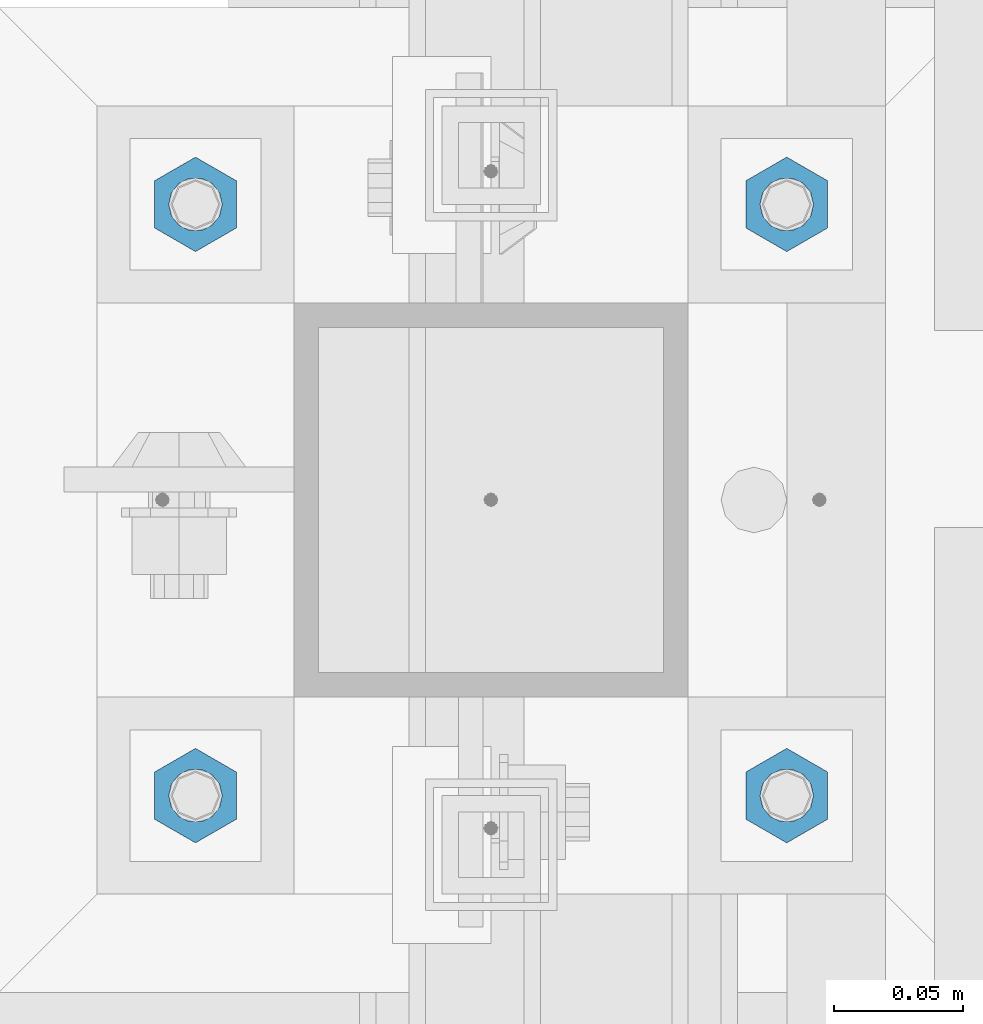
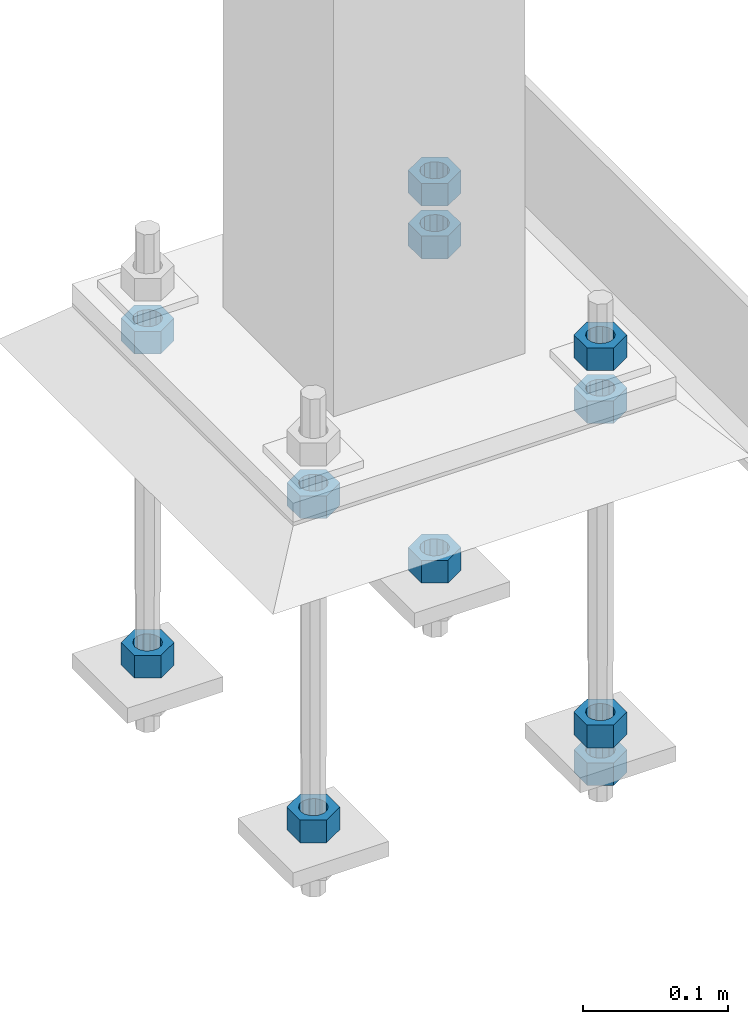
# One storey, part 2810 of 3843: 11 beams, 1 element without a shape of its own.
"""IFC2X3 building model written with IfcOpenShell, lengths in millimetres."""

import ifcopenshell
import ifcopenshell.guid

model = None  # the IFC model being written
_history = None  # IfcOwnerHistory: only IFC2X3 demands one
_inside = {}  # id of a spatial element -> (the spatial element, [elements in it])
_under = {}  # id of a project, library or spatial element -> (it, [spatial elements below it])
_declared = {}  # id of a project -> (the project, [libraries it declares])
_typed = {}  # id of a type object -> (the type object, [elements of that type])
_made_of = {}  # id of a material, layer set ... -> (it, [elements and type objects made of it])


def new_model(schema):
    """Start an empty IFC model of exactly this schema.

    Asked for "IFC4X3", IfcOpenShell would pick the latest addendum, in which some entities
    have other attributes; the version numbers below select the first issue.
    IFC2X3 requires an IfcOwnerHistory on every rooted entity: one is made here for all.
    """
    global model, _history
    if schema == "IFC4X3":
        model = ifcopenshell.file(schema_version=(4, 3, 0, 0))
    else:
        model = ifcopenshell.file(schema=schema)
    _inside.clear()
    _under.clear()
    _declared.clear()
    _typed.clear()
    _made_of.clear()
    _history = None
    if model.schema == "IFC2X3":
        org = make("IfcOrganization", Name="unknown")
        user = make(
            "IfcPersonAndOrganization",
            ThePerson=make("IfcPerson", FamilyName="unknown"),
            TheOrganization=org,
        )
        app = make(
            "IfcApplication",
            ApplicationDeveloper=org,
            Version="unknown",
            ApplicationFullName="unknown",
            ApplicationIdentifier="unknown",
        )
        _history = make(
            "IfcOwnerHistory",
            OwningUser=user,
            OwningApplication=app,
            ChangeAction="ADDED",
            CreationDate=0,
        )
    return model


def make(cls, **values):
    """One entity of the class cls with the attributes given. An attribute that is None is left unset."""
    return model.create_entity(
        cls, **{name: value for name, value in values.items() if value is not None}
    )


def rooted(cls, **values):
    """An entity with a GlobalId (a new one), such as an element, a storey or a relation."""
    return make(cls, GlobalId=ifcopenshell.guid.new(), OwnerHistory=_history, **values)


def si_unit(unit_type, name, prefix=None):
    """IfcSIUnit, for example si_unit("LENGTHUNIT", "METRE", prefix="MILLI")."""
    return make("IfcSIUnit", UnitType=unit_type, Prefix=prefix, Name=name)


def assignment(units):
    """IfcUnitAssignment: the units of a project."""
    return None if units is None else make("IfcUnitAssignment", Units=units)


def point(xyz):
    """IfcCartesianPoint."""
    return None if xyz is None else make("IfcCartesianPoint", Coordinates=xyz)


def direction(xyz):
    """IfcDirection."""
    return None if xyz is None else make("IfcDirection", DirectionRatios=xyz)


def frame(location, z_axis=None, x_axis=None):
    """IfcAxis2Placement3D, a coordinate frame: its origin and axes. An axis left out is left unset."""
    return make(
        "IfcAxis2Placement3D",
        Location=point(location),
        Axis=direction(z_axis),
        RefDirection=direction(x_axis),
    )


def origin_with_axes():
    """The frame at (0, 0, 0) with the z axis (0, 0, 1) and the x axis (1, 0, 0) written out."""
    return frame((0.0, 0.0, 0.0), z_axis=(0.0, 0.0, 1.0), x_axis=(1.0, 0.0, 0.0))


def place(relative_to, where):
    """IfcLocalPlacement: puts the frame where relative to a parent placement (None: the world)."""
    return make(
        "IfcLocalPlacement", PlacementRelTo=relative_to, RelativePlacement=where
    )


def context(
    kind, dimensions, precision=None, world=None, true_north=None, identifier=None
):
    """IfcGeometricRepresentationContext, for example the 3D "Model" context."""
    return make(
        "IfcGeometricRepresentationContext",
        ContextIdentifier=identifier,
        ContextType=kind,
        CoordinateSpaceDimension=dimensions,
        Precision=precision,
        WorldCoordinateSystem=world,
        TrueNorth=true_north,
    )


def subcontext(parent, identifier, kind, view, scale=None):
    """IfcGeometricRepresentationSubContext, for example "Body" below "Model"."""
    return make(
        "IfcGeometricRepresentationSubContext",
        ContextIdentifier=identifier,
        ContextType=kind,
        ParentContext=parent,
        TargetScale=scale,
        TargetView=view,
    )


def project(units=None, contexts=None):
    """IfcProject with its units and contexts."""
    return rooted(
        "IfcProject",
        Name="project",
        RepresentationContexts=contexts,
        UnitsInContext=assignment(units),
    )


def spatial(cls, under=None, at=None, **own):
    """A site, building, storey or space (cls), placed at a placement, below another one or the project."""
    s = rooted(cls, ObjectPlacement=at, **own)
    if under is not None:
        _under.setdefault(under.id(), (under, []))[1].append(s)
    return s


def faces_of(points, faces, orient=None, outer=None):
    """IfcFace entities. A face is a list of loops; a loop is a list of indices into points, from 0.

    orient and outer hold one flag for each loop. By default every Orientation is true, the
    first loop of a face is its IfcFaceOuterBound and the others are IfcFaceBound.
    """
    made = []
    for i, loops in enumerate(faces):
        bounds = []
        for j, loop in enumerate(loops):
            is_outer = j == 0 if outer is None else outer[i][j]
            bounds.append(
                make(
                    "IfcFaceOuterBound" if is_outer else "IfcFaceBound",
                    Bound=make("IfcPolyLoop", Polygon=[points[k] for k in loop]),
                    Orientation=True if orient is None else orient[i][j],
                )
            )
        made.append(make("IfcFace", Bounds=bounds))
    return made


def faceted_brep(points, faces, orient=None, outer=None, voids=None):
    """IfcFacetedBrep: a solid bounded by flat faces; with voids (closed shells), ...WithVoids."""
    shared = [point(p) for p in points]
    hull = make("IfcClosedShell", CfsFaces=faces_of(shared, faces, orient, outer))
    if voids is None:
        return make("IfcFacetedBrep", Outer=hull)
    return make(
        "IfcFacetedBrepWithVoids",
        Outer=hull,
        Voids=[
            make(cls, CfsFaces=faces_of(shared, fs, o, b)) for cls, fs, o, b in voids
        ],
    )


def shape(context_of_items, identifier, shape_type, items):
    """IfcShapeRepresentation: the items that make up one representation, for example the "Body"."""
    return make(
        "IfcShapeRepresentation",
        ContextOfItems=context_of_items,
        RepresentationIdentifier=identifier,
        RepresentationType=shape_type,
        Items=items,
    )


def material(Name=None, Category=None):
    """IfcMaterial."""
    return make("IfcMaterial", Name=Name, Category=Category)


def made_of(thing, what):
    """Note that an element or type object is made of a material, layer set ...; save() writes the relation."""
    if what is not None:
        _made_of.setdefault(what.id(), (what, []))[1].append(thing)
    return thing


def type_object(cls, material=None, **own):
    """A type object (cls), such as IfcWallType, which elements share."""
    return made_of(rooted(cls, **own), material)


def element(
    cls,
    number,
    at=None,
    inside=None,
    cuts=None,
    type_object=None,
    material=None,
    context=None,
    identifier="Body",
    shape_type=None,
    held_by="IfcProductDefinitionShape",
    body=None,
    shapes=None,
    **own,
):
    """One element of the class cls, such as IfcWall. Its Tag is "e" and its number.

    at: its placement. inside: the storey or other place that contains it. cuts: it is an
    opening in that element (IfcRelVoidsElement). A single representation is given by context,
    identifier, shape_type and body (its items); several are given by shapes. held_by: the class
    of the entity that holds the representations. save() writes the other relations.
    """
    e = rooted(cls, Tag="e%d" % number, ObjectPlacement=at, **own)
    if body is not None:
        shapes = [shape(context, identifier, shape_type, body)]
    if shapes is not None:
        e.Representation = make(held_by, Representations=shapes)
    if inside is not None:
        _inside.setdefault(inside.id(), (inside, []))[1].append(e)
    if cuts is not None:
        rooted(
            "IfcRelVoidsElement", RelatingBuildingElement=cuts, RelatedOpeningElement=e
        )
    if type_object is not None:
        _typed.setdefault(type_object.id(), (type_object, []))[1].append(e)
    return made_of(e, material)


def aggregate(whole, parts):
    """IfcRelAggregates: a whole, such as a stair, and the parts it consists of."""
    return rooted("IfcRelAggregates", RelatingObject=whole, RelatedObjects=parts)


def save(model, path):
    """Write the relations noted so far, then the file.

    IfcRelAggregates (storeys below a building ...), IfcRelContainedInSpatialStructure (elements
    in a storey), IfcRelDefinesByType, IfcRelAssociatesMaterial and IfcRelDeclares: one each for
    every whole, place, type object, material and project.
    """
    for whole, parts in _under.values():
        aggregate(whole, parts)
    for where, things in _inside.values():
        rooted(
            "IfcRelContainedInSpatialStructure",
            RelatedElements=things,
            RelatingStructure=where,
        )
    for kind, things in _typed.values():
        rooted("IfcRelDefinesByType", RelatedObjects=things, RelatingType=kind)
    for what, things in _made_of.values():
        rooted("IfcRelAssociatesMaterial", RelatedObjects=things, RelatingMaterial=what)
    for by, libraries in _declared.values():
        rooted("IfcRelDeclares", RelatingContext=by, RelatedDefinitions=libraries)
    model.write(path)


model = new_model("IFC2X3")

# Units and contexts
model_context = context("Model", 3, precision=1e-05, world=origin_with_axes())
body_context = subcontext(model_context, "Body", "Model", "MODEL_VIEW")
ifc_project = project(units=[si_unit("LENGTHUNIT", "METRE", prefix="MILLI"), si_unit("AREAUNIT", "SQUARE_METRE"), si_unit("VOLUMEUNIT", "CUBIC_METRE"), si_unit("MASSUNIT", "GRAM", prefix="KILO"), si_unit("TIMEUNIT", "SECOND"), si_unit("PLANEANGLEUNIT", "RADIAN"), si_unit("SOLIDANGLEUNIT", "STERADIAN"), si_unit("THERMODYNAMICTEMPERATUREUNIT", "DEGREE_CELSIUS"), si_unit("LUMINOUSINTENSITYUNIT", "LUMEN")], contexts=[model_context])

# Site, building, storey
site_placement = place(None, origin_with_axes())
site = spatial("IfcSite", under=ifc_project, at=site_placement, CompositionType="ELEMENT")
building_placement = place(site_placement, origin_with_axes())
building = spatial("IfcBuilding", under=site, at=building_placement, Name="Undefined", CompositionType="ELEMENT")
storey_placement = place(building_placement, origin_with_axes())
storey = spatial("IfcBuildingStorey", under=building, at=storey_placement, Name="Undefined", CompositionType="ELEMENT", Elevation=0.0)

# Assembly, beams
assembly_placement = place(storey_placement, origin_with_axes())
assembly = element("IfcElementAssembly", 1, at=assembly_placement, inside=storey, Name="TEMPLATE", AssemblyPlace="NOTDEFINED", PredefinedType="RIGID_FRAME")
ifc_material = material(Name="STEEL/A36")
beam_type = type_object("IfcBeamType", Name="3/4_HEAVY_HEX_NUT", PredefinedType="NOTDEFINED")
beam_1_placement = place(assembly_placement, frame((53105.05, 20193.0, 30518.1), z_axis=(1.0, 0.0, 0.0), x_axis=(0.0, 0.0, -1.0)))
beam_1 = element("IfcBeam", 2, at=beam_1_placement, type_object=beam_type, material=ifc_material, Name="NUT", ObjectType="3/4_HEAVY_HEX_NUT", context=body_context, shape_type="Brep", body=[
    faceted_brep([(0.0, -18.2600002288818, 0.0), (0.0, -9.13000011444092, -15.8100004196167), (19.0500000000029, -9.13000011444092, -15.8100004196167), (19.0500000000029, -18.2600002288818, 0.0), (0.0, 9.13000011444092, -15.8100004196167), (19.0500000000029, 9.13000011444092, -15.8100004196167), (0.0, 18.2600002288818, 0.0), (19.0500000000029, 18.2600002288818, 0.0), (0.0, 9.13000011444092, 15.8100004196167), (19.0500000000029, 9.13000011444092, 15.8100004196167), (0.0, -9.13000011444092, 15.8100004196167), (19.0500000000029, -9.13000011444092, 15.8100004196167), (0.0, 0.0, 10.3199996948242), (0.0, 4.47768005527905, 9.29799844179797), (19.0500000000029, 4.47768005527905, 9.29799844179797), (19.0500000000029, 0.0, 10.3199996948242), (0.0, 8.06850066047627, 6.43441456490837), (19.0500000000029, 8.06850066047627, 6.43441456490837), (0.0, 10.0612557561908, 2.2964159705225), (19.0500000000029, 10.0612557561908, 2.2964159705225), (0.0, 10.0612557561908, -2.2964159705225), (19.0500000000029, 10.0612557561908, -2.2964159705225), (0.0, 8.06850066047627, -6.43441456490837), (19.0500000000029, 8.06850066047627, -6.43441456490837), (0.0, 4.47768005527905, -9.29799844179797), (19.0500000000029, 4.47768005527905, -9.29799844179797), (0.0, 0.0, -10.3199996948242), (19.0500000000029, 0.0, -10.3199996948242), (0.0, -4.47768005527905, -9.29799844179797), (19.0500000000029, -4.47768005527905, -9.29799844179797), (0.0, -8.06850066047627, -6.43441456490837), (19.0500000000029, -8.06850066047627, -6.43441456490837), (0.0, -10.0612557561908, -2.2964159705225), (19.0500000000029, -10.0612557561908, -2.2964159705225), (0.0, -10.0612557561908, 2.2964159705225), (19.0500000000029, -10.0612557561908, 2.2964159705225), (0.0, -8.06850066047627, 6.43441456490837), (19.0500000000029, -8.06850066047627, 6.43441456490837), (0.0, -4.47768005527905, 9.29799844179797), (19.0500000000029, -4.47768005527905, 9.29799844179797)], [[[0, 1, 2, 3]], [[1, 4, 5, 2]], [[4, 6, 7, 5]], [[6, 8, 9, 7]], [[8, 10, 11, 9]], [[10, 0, 3, 11]], [[12, 13, 14, 15]], [[13, 16, 17, 14]], [[16, 18, 19, 17]], [[18, 20, 21, 19]], [[20, 22, 23, 21]], [[22, 24, 25, 23]], [[24, 26, 27, 25]], [[26, 28, 29, 27]], [[28, 30, 31, 29]], [[30, 32, 33, 31]], [[32, 34, 35, 33]], [[34, 36, 37, 35]], [[36, 38, 39, 37]], [[38, 12, 15, 39]], [[5, 7, 9, 11, 3, 2], [17, 19, 21, 23, 25, 27, 29, 31, 33, 35, 37, 39, 15, 14]], [[10, 8, 6, 4, 1, 0], [38, 36, 34, 32, 30, 28, 26, 24, 22, 20, 18, 16, 13, 12]]]),
])
beam_2_placement = place(assembly_placement, frame((53105.05, 20193.0, 30245.05), z_axis=(1.0, 0.0, 0.0), x_axis=(0.0, 0.0, -1.0)))
beam_2 = element("IfcBeam", 3, at=beam_2_placement, type_object=beam_type, material=ifc_material, Name="NUT", ObjectType="3/4_HEAVY_HEX_NUT", context=body_context, shape_type="Brep", body=[
    faceted_brep([(0.0, -18.2600002288818, 0.0), (0.0, -9.13000011444092, -15.8100004196167), (19.0500000000029, -9.13000011444092, -15.8100004196167), (19.0500000000029, -18.2600002288818, 0.0), (0.0, 9.13000011444092, -15.8100004196167), (19.0500000000029, 9.13000011444092, -15.8100004196167), (0.0, 18.2600002288818, 0.0), (19.0500000000029, 18.2600002288818, 0.0), (0.0, 9.13000011444092, 15.8100004196167), (19.0500000000029, 9.13000011444092, 15.8100004196167), (0.0, -9.13000011444092, 15.8100004196167), (19.0500000000029, -9.13000011444092, 15.8100004196167), (0.0, 0.0, 10.3199996948242), (0.0, 4.47768005527905, 9.29799844179797), (19.0500000000029, 4.47768005527905, 9.29799844179797), (19.0500000000029, 0.0, 10.3199996948242), (0.0, 8.06850066047627, 6.43441456490837), (19.0500000000029, 8.06850066047627, 6.43441456490837), (0.0, 10.0612557561908, 2.2964159705225), (19.0500000000029, 10.0612557561908, 2.2964159705225), (0.0, 10.0612557561908, -2.2964159705225), (19.0500000000029, 10.0612557561908, -2.2964159705225), (0.0, 8.06850066047627, -6.43441456490837), (19.0500000000029, 8.06850066047627, -6.43441456490837), (0.0, 4.47768005527905, -9.29799844179797), (19.0500000000029, 4.47768005527905, -9.29799844179797), (0.0, 0.0, -10.3199996948242), (19.0500000000029, 0.0, -10.3199996948242), (0.0, -4.47768005527905, -9.29799844179797), (19.0500000000029, -4.47768005527905, -9.29799844179797), (0.0, -8.06850066047627, -6.43441456490837), (19.0500000000029, -8.06850066047627, -6.43441456490837), (0.0, -10.0612557561908, -2.2964159705225), (19.0500000000029, -10.0612557561908, -2.2964159705225), (0.0, -10.0612557561908, 2.2964159705225), (19.0500000000029, -10.0612557561908, 2.2964159705225), (0.0, -8.06850066047627, 6.43441456490837), (19.0500000000029, -8.06850066047627, 6.43441456490837), (0.0, -4.47768005527905, 9.29799844179797), (19.0500000000029, -4.47768005527905, 9.29799844179797)], [[[0, 1, 2, 3]], [[1, 4, 5, 2]], [[4, 6, 7, 5]], [[6, 8, 9, 7]], [[8, 10, 11, 9]], [[10, 0, 3, 11]], [[12, 13, 14, 15]], [[13, 16, 17, 14]], [[16, 18, 19, 17]], [[18, 20, 21, 19]], [[20, 22, 23, 21]], [[22, 24, 25, 23]], [[24, 26, 27, 25]], [[26, 28, 29, 27]], [[28, 30, 31, 29]], [[30, 32, 33, 31]], [[32, 34, 35, 33]], [[34, 36, 37, 35]], [[36, 38, 39, 37]], [[38, 12, 15, 39]], [[5, 7, 9, 11, 3, 2], [17, 19, 21, 23, 25, 27, 29, 31, 33, 35, 37, 39, 15, 14]], [[10, 8, 6, 4, 1, 0], [38, 36, 34, 32, 30, 28, 26, 24, 22, 20, 18, 16, 13, 12]]]),
])
beam_3_placement = place(assembly_placement, frame((53105.05, 20421.6, 30518.1), z_axis=(-1.0, 0.0, 0.0), x_axis=(0.0, 0.0, -1.0)))
beam_3 = element("IfcBeam", 4, at=beam_3_placement, type_object=beam_type, material=ifc_material, Name="NUT", ObjectType="3/4_HEAVY_HEX_NUT", context=body_context, shape_type="Brep", body=[
    faceted_brep([(0.0, -18.2600002288818, 0.0), (0.0, -9.13000011444092, -15.8100004196167), (19.0500000000029, -9.13000011444092, -15.8100004196167), (19.0500000000029, -18.2600002288818, 0.0), (0.0, 9.13000011444092, -15.8100004196167), (19.0500000000029, 9.13000011444092, -15.8100004196167), (0.0, 18.2600002288818, 0.0), (19.0500000000029, 18.2600002288818, 0.0), (0.0, 9.13000011444092, 15.8100004196167), (19.0500000000029, 9.13000011444092, 15.8100004196167), (0.0, -9.13000011444092, 15.8100004196167), (19.0500000000029, -9.13000011444092, 15.8100004196167), (0.0, 0.0, 10.3199996948242), (0.0, 4.47768005527905, 9.29799844179797), (19.0500000000029, 4.47768005527905, 9.29799844179797), (19.0500000000029, 0.0, 10.3199996948242), (0.0, 8.06850066047627, 6.43441456490837), (19.0500000000029, 8.06850066047627, 6.43441456490837), (0.0, 10.0612557561908, 2.2964159705225), (19.0500000000029, 10.0612557561908, 2.2964159705225), (0.0, 10.0612557561908, -2.2964159705225), (19.0500000000029, 10.0612557561908, -2.2964159705225), (0.0, 8.06850066047627, -6.43441456490837), (19.0500000000029, 8.06850066047627, -6.43441456490837), (0.0, 4.47768005527905, -9.29799844179797), (19.0500000000029, 4.47768005527905, -9.29799844179797), (0.0, 0.0, -10.3199996948242), (19.0500000000029, 0.0, -10.3199996948242), (0.0, -4.47768005527905, -9.29799844179797), (19.0500000000029, -4.47768005527905, -9.29799844179797), (0.0, -8.06850066047627, -6.43441456490837), (19.0500000000029, -8.06850066047627, -6.43441456490837), (0.0, -10.0612557561908, -2.2964159705225), (19.0500000000029, -10.0612557561908, -2.2964159705225), (0.0, -10.0612557561908, 2.2964159705225), (19.0500000000029, -10.0612557561908, 2.2964159705225), (0.0, -8.06850066047627, 6.43441456490837), (19.0500000000029, -8.06850066047627, 6.43441456490837), (0.0, -4.47768005527905, 9.29799844179797), (19.0500000000029, -4.47768005527905, 9.29799844179797)], [[[0, 1, 2, 3]], [[1, 4, 5, 2]], [[4, 6, 7, 5]], [[6, 8, 9, 7]], [[8, 10, 11, 9]], [[10, 0, 3, 11]], [[12, 13, 14, 15]], [[13, 16, 17, 14]], [[16, 18, 19, 17]], [[18, 20, 21, 19]], [[20, 22, 23, 21]], [[22, 24, 25, 23]], [[24, 26, 27, 25]], [[26, 28, 29, 27]], [[28, 30, 31, 29]], [[30, 32, 33, 31]], [[32, 34, 35, 33]], [[34, 36, 37, 35]], [[36, 38, 39, 37]], [[38, 12, 15, 39]], [[5, 7, 9, 11, 3, 2], [17, 19, 21, 23, 25, 27, 29, 31, 33, 35, 37, 39, 15, 14]], [[10, 8, 6, 4, 1, 0], [38, 36, 34, 32, 30, 28, 26, 24, 22, 20, 18, 16, 13, 12]]]),
])
beam_4_placement = place(assembly_placement, frame((53105.05, 20421.6, 30245.05), z_axis=(-1.0, 0.0, 0.0), x_axis=(0.0, 0.0, -1.0)))
beam_4 = element("IfcBeam", 5, at=beam_4_placement, type_object=beam_type, material=ifc_material, Name="NUT", ObjectType="3/4_HEAVY_HEX_NUT", context=body_context, shape_type="Brep", body=[
    faceted_brep([(0.0, -18.2600002288818, 0.0), (0.0, -9.13000011444092, -15.8100004196167), (19.0500000000029, -9.13000011444092, -15.8100004196167), (19.0500000000029, -18.2600002288818, 0.0), (0.0, 9.13000011444092, -15.8100004196167), (19.0500000000029, 9.13000011444092, -15.8100004196167), (0.0, 18.2600002288818, 0.0), (19.0500000000029, 18.2600002288818, 0.0), (0.0, 9.13000011444092, 15.8100004196167), (19.0500000000029, 9.13000011444092, 15.8100004196167), (0.0, -9.13000011444092, 15.8100004196167), (19.0500000000029, -9.13000011444092, 15.8100004196167), (0.0, 0.0, 10.3199996948242), (0.0, 4.47768005527905, 9.29799844179797), (19.0500000000029, 4.47768005527905, 9.29799844179797), (19.0500000000029, 0.0, 10.3199996948242), (0.0, 8.06850066047627, 6.43441456490837), (19.0500000000029, 8.06850066047627, 6.43441456490837), (0.0, 10.0612557561908, 2.2964159705225), (19.0500000000029, 10.0612557561908, 2.2964159705225), (0.0, 10.0612557561908, -2.2964159705225), (19.0500000000029, 10.0612557561908, -2.2964159705225), (0.0, 8.06850066047627, -6.43441456490837), (19.0500000000029, 8.06850066047627, -6.43441456490837), (0.0, 4.47768005527905, -9.29799844179797), (19.0500000000029, 4.47768005527905, -9.29799844179797), (0.0, 0.0, -10.3199996948242), (19.0500000000029, 0.0, -10.3199996948242), (0.0, -4.47768005527905, -9.29799844179797), (19.0500000000029, -4.47768005527905, -9.29799844179797), (0.0, -8.06850066047627, -6.43441456490837), (19.0500000000029, -8.06850066047627, -6.43441456490837), (0.0, -10.0612557561908, -2.2964159705225), (19.0500000000029, -10.0612557561908, -2.2964159705225), (0.0, -10.0612557561908, 2.2964159705225), (19.0500000000029, -10.0612557561908, 2.2964159705225), (0.0, -8.06850066047627, 6.43441456490837), (19.0500000000029, -8.06850066047627, 6.43441456490837), (0.0, -4.47768005527905, 9.29799844179797), (19.0500000000029, -4.47768005527905, 9.29799844179797)], [[[0, 1, 2, 3]], [[1, 4, 5, 2]], [[4, 6, 7, 5]], [[6, 8, 9, 7]], [[8, 10, 11, 9]], [[10, 0, 3, 11]], [[12, 13, 14, 15]], [[13, 16, 17, 14]], [[16, 18, 19, 17]], [[18, 20, 21, 19]], [[20, 22, 23, 21]], [[22, 24, 25, 23]], [[24, 26, 27, 25]], [[26, 28, 29, 27]], [[28, 30, 31, 29]], [[30, 32, 33, 31]], [[32, 34, 35, 33]], [[34, 36, 37, 35]], [[36, 38, 39, 37]], [[38, 12, 15, 39]], [[5, 7, 9, 11, 3, 2], [17, 19, 21, 23, 25, 27, 29, 31, 33, 35, 37, 39, 15, 14]], [[10, 8, 6, 4, 1, 0], [38, 36, 34, 32, 30, 28, 26, 24, 22, 20, 18, 16, 13, 12]]]),
])
beam_5_placement = place(assembly_placement, frame((52876.45, 20193.0, 30518.1), z_axis=(1.0, 0.0, 0.0), x_axis=(0.0, 0.0, -1.0)))
beam_5 = element("IfcBeam", 6, at=beam_5_placement, type_object=beam_type, material=ifc_material, Name="NUT", ObjectType="3/4_HEAVY_HEX_NUT", context=body_context, shape_type="Brep", body=[
    faceted_brep([(0.0, -18.2600002288818, 0.0), (0.0, -9.13000011444092, -15.8100004196167), (19.0500000000029, -9.13000011444092, -15.8100004196167), (19.0500000000029, -18.2600002288818, 0.0), (0.0, 9.13000011444092, -15.8100004196167), (19.0500000000029, 9.13000011444092, -15.8100004196167), (0.0, 18.2600002288818, 0.0), (19.0500000000029, 18.2600002288818, 0.0), (0.0, 9.13000011444092, 15.8100004196167), (19.0500000000029, 9.13000011444092, 15.8100004196167), (0.0, -9.13000011444092, 15.8100004196167), (19.0500000000029, -9.13000011444092, 15.8100004196167), (0.0, 0.0, 10.3199996948242), (0.0, 4.47768005527905, 9.29799844179797), (19.0500000000029, 4.47768005527905, 9.29799844179797), (19.0500000000029, 0.0, 10.3199996948242), (0.0, 8.06850066047627, 6.43441456490837), (19.0500000000029, 8.06850066047627, 6.43441456490837), (0.0, 10.0612557561908, 2.2964159705225), (19.0500000000029, 10.0612557561908, 2.2964159705225), (0.0, 10.0612557561908, -2.2964159705225), (19.0500000000029, 10.0612557561908, -2.2964159705225), (0.0, 8.06850066047627, -6.43441456490837), (19.0500000000029, 8.06850066047627, -6.43441456490837), (0.0, 4.47768005527905, -9.29799844179797), (19.0500000000029, 4.47768005527905, -9.29799844179797), (0.0, 0.0, -10.3199996948242), (19.0500000000029, 0.0, -10.3199996948242), (0.0, -4.47768005527905, -9.29799844179797), (19.0500000000029, -4.47768005527905, -9.29799844179797), (0.0, -8.06850066047627, -6.43441456490837), (19.0500000000029, -8.06850066047627, -6.43441456490837), (0.0, -10.0612557561908, -2.2964159705225), (19.0500000000029, -10.0612557561908, -2.2964159705225), (0.0, -10.0612557561908, 2.2964159705225), (19.0500000000029, -10.0612557561908, 2.2964159705225), (0.0, -8.06850066047627, 6.43441456490837), (19.0500000000029, -8.06850066047627, 6.43441456490837), (0.0, -4.47768005527905, 9.29799844179797), (19.0500000000029, -4.47768005527905, 9.29799844179797)], [[[0, 1, 2, 3]], [[1, 4, 5, 2]], [[4, 6, 7, 5]], [[6, 8, 9, 7]], [[8, 10, 11, 9]], [[10, 0, 3, 11]], [[12, 13, 14, 15]], [[13, 16, 17, 14]], [[16, 18, 19, 17]], [[18, 20, 21, 19]], [[20, 22, 23, 21]], [[22, 24, 25, 23]], [[24, 26, 27, 25]], [[26, 28, 29, 27]], [[28, 30, 31, 29]], [[30, 32, 33, 31]], [[32, 34, 35, 33]], [[34, 36, 37, 35]], [[36, 38, 39, 37]], [[38, 12, 15, 39]], [[5, 7, 9, 11, 3, 2], [17, 19, 21, 23, 25, 27, 29, 31, 33, 35, 37, 39, 15, 14]], [[10, 8, 6, 4, 1, 0], [38, 36, 34, 32, 30, 28, 26, 24, 22, 20, 18, 16, 13, 12]]]),
])
beam_6_placement = place(assembly_placement, frame((52876.45, 20193.0, 30245.05), z_axis=(1.0, 0.0, 0.0), x_axis=(0.0, 0.0, -1.0)))
beam_6 = element("IfcBeam", 7, at=beam_6_placement, type_object=beam_type, material=ifc_material, Name="NUT", ObjectType="3/4_HEAVY_HEX_NUT", context=body_context, shape_type="Brep", body=[
    faceted_brep([(0.0, -18.2600002288818, 0.0), (0.0, -9.13000011444092, -15.8100004196167), (19.0500000000029, -9.13000011444092, -15.8100004196167), (19.0500000000029, -18.2600002288818, 0.0), (0.0, 9.13000011444092, -15.8100004196167), (19.0500000000029, 9.13000011444092, -15.8100004196167), (0.0, 18.2600002288818, 0.0), (19.0500000000029, 18.2600002288818, 0.0), (0.0, 9.13000011444092, 15.8100004196167), (19.0500000000029, 9.13000011444092, 15.8100004196167), (0.0, -9.13000011444092, 15.8100004196167), (19.0500000000029, -9.13000011444092, 15.8100004196167), (0.0, 0.0, 10.3199996948242), (0.0, 4.47768005527905, 9.29799844179797), (19.0500000000029, 4.47768005527905, 9.29799844179797), (19.0500000000029, 0.0, 10.3199996948242), (0.0, 8.06850066047627, 6.43441456490837), (19.0500000000029, 8.06850066047627, 6.43441456490837), (0.0, 10.0612557561908, 2.2964159705225), (19.0500000000029, 10.0612557561908, 2.2964159705225), (0.0, 10.0612557561908, -2.2964159705225), (19.0500000000029, 10.0612557561908, -2.2964159705225), (0.0, 8.06850066047627, -6.43441456490837), (19.0500000000029, 8.06850066047627, -6.43441456490837), (0.0, 4.47768005527905, -9.29799844179797), (19.0500000000029, 4.47768005527905, -9.29799844179797), (0.0, 0.0, -10.3199996948242), (19.0500000000029, 0.0, -10.3199996948242), (0.0, -4.47768005527905, -9.29799844179797), (19.0500000000029, -4.47768005527905, -9.29799844179797), (0.0, -8.06850066047627, -6.43441456490837), (19.0500000000029, -8.06850066047627, -6.43441456490837), (0.0, -10.0612557561908, -2.2964159705225), (19.0500000000029, -10.0612557561908, -2.2964159705225), (0.0, -10.0612557561908, 2.2964159705225), (19.0500000000029, -10.0612557561908, 2.2964159705225), (0.0, -8.06850066047627, 6.43441456490837), (19.0500000000029, -8.06850066047627, 6.43441456490837), (0.0, -4.47768005527905, 9.29799844179797), (19.0500000000029, -4.47768005527905, 9.29799844179797)], [[[0, 1, 2, 3]], [[1, 4, 5, 2]], [[4, 6, 7, 5]], [[6, 8, 9, 7]], [[8, 10, 11, 9]], [[10, 0, 3, 11]], [[12, 13, 14, 15]], [[13, 16, 17, 14]], [[16, 18, 19, 17]], [[18, 20, 21, 19]], [[20, 22, 23, 21]], [[22, 24, 25, 23]], [[24, 26, 27, 25]], [[26, 28, 29, 27]], [[28, 30, 31, 29]], [[30, 32, 33, 31]], [[32, 34, 35, 33]], [[34, 36, 37, 35]], [[36, 38, 39, 37]], [[38, 12, 15, 39]], [[5, 7, 9, 11, 3, 2], [17, 19, 21, 23, 25, 27, 29, 31, 33, 35, 37, 39, 15, 14]], [[10, 8, 6, 4, 1, 0], [38, 36, 34, 32, 30, 28, 26, 24, 22, 20, 18, 16, 13, 12]]]),
])
beam_7_placement = place(assembly_placement, frame((52876.45, 20421.6, 30518.1), z_axis=(-1.0, 0.0, 0.0), x_axis=(0.0, 0.0, -1.0)))
beam_7 = element("IfcBeam", 8, at=beam_7_placement, type_object=beam_type, material=ifc_material, Name="NUT", ObjectType="3/4_HEAVY_HEX_NUT", context=body_context, shape_type="Brep", body=[
    faceted_brep([(0.0, -18.2600002288818, 0.0), (0.0, -9.13000011444092, -15.8100004196167), (19.0500000000029, -9.13000011444092, -15.8100004196167), (19.0500000000029, -18.2600002288818, 0.0), (0.0, 9.13000011444092, -15.8100004196167), (19.0500000000029, 9.13000011444092, -15.8100004196167), (0.0, 18.2600002288818, 0.0), (19.0500000000029, 18.2600002288818, 0.0), (0.0, 9.13000011444092, 15.8100004196167), (19.0500000000029, 9.13000011444092, 15.8100004196167), (0.0, -9.13000011444092, 15.8100004196167), (19.0500000000029, -9.13000011444092, 15.8100004196167), (0.0, 0.0, 10.3199996948242), (0.0, 4.47768005527905, 9.29799844179797), (19.0500000000029, 4.47768005527905, 9.29799844179797), (19.0500000000029, 0.0, 10.3199996948242), (0.0, 8.06850066047627, 6.43441456490837), (19.0500000000029, 8.06850066047627, 6.43441456490837), (0.0, 10.0612557561908, 2.2964159705225), (19.0500000000029, 10.0612557561908, 2.2964159705225), (0.0, 10.0612557561908, -2.2964159705225), (19.0500000000029, 10.0612557561908, -2.2964159705225), (0.0, 8.06850066047627, -6.43441456490837), (19.0500000000029, 8.06850066047627, -6.43441456490837), (0.0, 4.47768005527905, -9.29799844179797), (19.0500000000029, 4.47768005527905, -9.29799844179797), (0.0, 0.0, -10.3199996948242), (19.0500000000029, 0.0, -10.3199996948242), (0.0, -4.47768005527905, -9.29799844179797), (19.0500000000029, -4.47768005527905, -9.29799844179797), (0.0, -8.06850066047627, -6.43441456490837), (19.0500000000029, -8.06850066047627, -6.43441456490837), (0.0, -10.0612557561908, -2.2964159705225), (19.0500000000029, -10.0612557561908, -2.2964159705225), (0.0, -10.0612557561908, 2.2964159705225), (19.0500000000029, -10.0612557561908, 2.2964159705225), (0.0, -8.06850066047627, 6.43441456490837), (19.0500000000029, -8.06850066047627, 6.43441456490837), (0.0, -4.47768005527905, 9.29799844179797), (19.0500000000029, -4.47768005527905, 9.29799844179797)], [[[0, 1, 2, 3]], [[1, 4, 5, 2]], [[4, 6, 7, 5]], [[6, 8, 9, 7]], [[8, 10, 11, 9]], [[10, 0, 3, 11]], [[12, 13, 14, 15]], [[13, 16, 17, 14]], [[16, 18, 19, 17]], [[18, 20, 21, 19]], [[20, 22, 23, 21]], [[22, 24, 25, 23]], [[24, 26, 27, 25]], [[26, 28, 29, 27]], [[28, 30, 31, 29]], [[30, 32, 33, 31]], [[32, 34, 35, 33]], [[34, 36, 37, 35]], [[36, 38, 39, 37]], [[38, 12, 15, 39]], [[5, 7, 9, 11, 3, 2], [17, 19, 21, 23, 25, 27, 29, 31, 33, 35, 37, 39, 15, 14]], [[10, 8, 6, 4, 1, 0], [38, 36, 34, 32, 30, 28, 26, 24, 22, 20, 18, 16, 13, 12]]]),
])
beam_8_placement = place(assembly_placement, frame((52876.45, 20421.6, 30245.05), z_axis=(-1.0, 0.0, 0.0), x_axis=(0.0, 0.0, -1.0)))
beam_8 = element("IfcBeam", 9, at=beam_8_placement, type_object=beam_type, material=ifc_material, Name="NUT", ObjectType="3/4_HEAVY_HEX_NUT", context=body_context, shape_type="Brep", body=[
    faceted_brep([(0.0, -18.2600002288818, 0.0), (0.0, -9.13000011444092, -15.8100004196167), (19.0500000000029, -9.13000011444092, -15.8100004196167), (19.0500000000029, -18.2600002288818, 0.0), (0.0, 9.13000011444092, -15.8100004196167), (19.0500000000029, 9.13000011444092, -15.8100004196167), (0.0, 18.2600002288818, 0.0), (19.0500000000029, 18.2600002288818, 0.0), (0.0, 9.13000011444092, 15.8100004196167), (19.0500000000029, 9.13000011444092, 15.8100004196167), (0.0, -9.13000011444092, 15.8100004196167), (19.0500000000029, -9.13000011444092, 15.8100004196167), (0.0, 0.0, 10.3199996948242), (0.0, 4.47768005527905, 9.29799844179797), (19.0500000000029, 4.47768005527905, 9.29799844179797), (19.0500000000029, 0.0, 10.3199996948242), (0.0, 8.06850066047627, 6.43441456490837), (19.0500000000029, 8.06850066047627, 6.43441456490837), (0.0, 10.0612557561908, 2.2964159705225), (19.0500000000029, 10.0612557561908, 2.2964159705225), (0.0, 10.0612557561908, -2.2964159705225), (19.0500000000029, 10.0612557561908, -2.2964159705225), (0.0, 8.06850066047627, -6.43441456490837), (19.0500000000029, 8.06850066047627, -6.43441456490837), (0.0, 4.47768005527905, -9.29799844179797), (19.0500000000029, 4.47768005527905, -9.29799844179797), (0.0, 0.0, -10.3199996948242), (19.0500000000029, 0.0, -10.3199996948242), (0.0, -4.47768005527905, -9.29799844179797), (19.0500000000029, -4.47768005527905, -9.29799844179797), (0.0, -8.06850066047627, -6.43441456490837), (19.0500000000029, -8.06850066047627, -6.43441456490837), (0.0, -10.0612557561908, -2.2964159705225), (19.0500000000029, -10.0612557561908, -2.2964159705225), (0.0, -10.0612557561908, 2.2964159705225), (19.0500000000029, -10.0612557561908, 2.2964159705225), (0.0, -8.06850066047627, 6.43441456490837), (19.0500000000029, -8.06850066047627, 6.43441456490837), (0.0, -4.47768005527905, 9.29799844179797), (19.0500000000029, -4.47768005527905, 9.29799844179797)], [[[0, 1, 2, 3]], [[1, 4, 5, 2]], [[4, 6, 7, 5]], [[6, 8, 9, 7]], [[8, 10, 11, 9]], [[10, 0, 3, 11]], [[12, 13, 14, 15]], [[13, 16, 17, 14]], [[16, 18, 19, 17]], [[18, 20, 21, 19]], [[20, 22, 23, 21]], [[22, 24, 25, 23]], [[24, 26, 27, 25]], [[26, 28, 29, 27]], [[28, 30, 31, 29]], [[30, 32, 33, 31]], [[32, 34, 35, 33]], [[34, 36, 37, 35]], [[36, 38, 39, 37]], [[38, 12, 15, 39]], [[5, 7, 9, 11, 3, 2], [17, 19, 21, 23, 25, 27, 29, 31, 33, 35, 37, 39, 15, 14]], [[10, 8, 6, 4, 1, 0], [38, 36, 34, 32, 30, 28, 26, 24, 22, 20, 18, 16, 13, 12]]]),
])
beam_9_placement = place(assembly_placement, frame((53105.05, 20193.0, 30562.55), z_axis=(1.0, 0.0, 0.0), x_axis=(0.0, 0.0, -1.0)))
beam_9 = element("IfcBeam", 10, at=beam_9_placement, type_object=beam_type, material=ifc_material, Name="NUT", ObjectType="3/4_HEAVY_HEX_NUT", context=body_context, shape_type="Brep", body=[
    faceted_brep([(0.0, -18.2600002288818, 0.0), (0.0, -9.13000011444092, -15.8100004196167), (19.0500000000029, -9.13000011444092, -15.8100004196167), (19.0500000000029, -18.2600002288818, 0.0), (0.0, 9.13000011444092, -15.8100004196167), (19.0500000000029, 9.13000011444092, -15.8100004196167), (0.0, 18.2600002288818, 0.0), (19.0500000000029, 18.2600002288818, 0.0), (0.0, 9.13000011444092, 15.8100004196167), (19.0500000000029, 9.13000011444092, 15.8100004196167), (0.0, -9.13000011444092, 15.8100004196167), (19.0500000000029, -9.13000011444092, 15.8100004196167), (0.0, 0.0, 10.3199996948242), (0.0, 4.47768005527905, 9.29799844179797), (19.0500000000029, 4.47768005527905, 9.29799844179797), (19.0500000000029, 0.0, 10.3199996948242), (0.0, 8.06850066047627, 6.43441456490837), (19.0500000000029, 8.06850066047627, 6.43441456490837), (0.0, 10.0612557561908, 2.2964159705225), (19.0500000000029, 10.0612557561908, 2.2964159705225), (0.0, 10.0612557561908, -2.2964159705225), (19.0500000000029, 10.0612557561908, -2.2964159705225), (0.0, 8.06850066047627, -6.43441456490837), (19.0500000000029, 8.06850066047627, -6.43441456490837), (0.0, 4.47768005527905, -9.29799844179797), (19.0500000000029, 4.47768005527905, -9.29799844179797), (0.0, 0.0, -10.3199996948242), (19.0500000000029, 0.0, -10.3199996948242), (0.0, -4.47768005527905, -9.29799844179797), (19.0500000000029, -4.47768005527905, -9.29799844179797), (0.0, -8.06850066047627, -6.43441456490837), (19.0500000000029, -8.06850066047627, -6.43441456490837), (0.0, -10.0612557561908, -2.2964159705225), (19.0500000000029, -10.0612557561908, -2.2964159705225), (0.0, -10.0612557561908, 2.2964159705225), (19.0500000000029, -10.0612557561908, 2.2964159705225), (0.0, -8.06850066047627, 6.43441456490837), (19.0500000000029, -8.06850066047627, 6.43441456490837), (0.0, -4.47768005527905, 9.29799844179797), (19.0500000000029, -4.47768005527905, 9.29799844179797)], [[[0, 1, 2, 3]], [[1, 4, 5, 2]], [[4, 6, 7, 5]], [[6, 8, 9, 7]], [[8, 10, 11, 9]], [[10, 0, 3, 11]], [[12, 13, 14, 15]], [[13, 16, 17, 14]], [[16, 18, 19, 17]], [[18, 20, 21, 19]], [[20, 22, 23, 21]], [[22, 24, 25, 23]], [[24, 26, 27, 25]], [[26, 28, 29, 27]], [[28, 30, 31, 29]], [[30, 32, 33, 31]], [[32, 34, 35, 33]], [[34, 36, 37, 35]], [[36, 38, 39, 37]], [[38, 12, 15, 39]], [[5, 7, 9, 11, 3, 2], [17, 19, 21, 23, 25, 27, 29, 31, 33, 35, 37, 39, 15, 14]], [[10, 8, 6, 4, 1, 0], [38, 36, 34, 32, 30, 28, 26, 24, 22, 20, 18, 16, 13, 12]]]),
])
beam_10_placement = place(assembly_placement, frame((53105.05, 20193.0, 30213.3), z_axis=(1.0, 0.0, 0.0), x_axis=(0.0, 0.0, -1.0)))
beam_10 = element("IfcBeam", 11, at=beam_10_placement, type_object=beam_type, material=ifc_material, Name="NUT", ObjectType="3/4_HEAVY_HEX_NUT", context=body_context, shape_type="Brep", body=[
    faceted_brep([(0.0, -18.2600002288818, 0.0), (0.0, -9.13000011444092, -15.8100004196167), (19.0500000000029, -9.13000011444092, -15.8100004196167), (19.0500000000029, -18.2600002288818, 0.0), (0.0, 9.13000011444092, -15.8100004196167), (19.0500000000029, 9.13000011444092, -15.8100004196167), (0.0, 18.2600002288818, 0.0), (19.0500000000029, 18.2600002288818, 0.0), (0.0, 9.13000011444092, 15.8100004196167), (19.0500000000029, 9.13000011444092, 15.8100004196167), (0.0, -9.13000011444092, 15.8100004196167), (19.0500000000029, -9.13000011444092, 15.8100004196167), (0.0, 0.0, 10.3199996948242), (0.0, 4.47768005527905, 9.29799844179797), (19.0500000000029, 4.47768005527905, 9.29799844179797), (19.0500000000029, 0.0, 10.3199996948242), (0.0, 8.06850066047627, 6.43441456490837), (19.0500000000029, 8.06850066047627, 6.43441456490837), (0.0, 10.0612557561908, 2.2964159705225), (19.0500000000029, 10.0612557561908, 2.2964159705225), (0.0, 10.0612557561908, -2.2964159705225), (19.0500000000029, 10.0612557561908, -2.2964159705225), (0.0, 8.06850066047627, -6.43441456490837), (19.0500000000029, 8.06850066047627, -6.43441456490837), (0.0, 4.47768005527905, -9.29799844179797), (19.0500000000029, 4.47768005527905, -9.29799844179797), (0.0, 0.0, -10.3199996948242), (19.0500000000029, 0.0, -10.3199996948242), (0.0, -4.47768005527905, -9.29799844179797), (19.0500000000029, -4.47768005527905, -9.29799844179797), (0.0, -8.06850066047627, -6.43441456490837), (19.0500000000029, -8.06850066047627, -6.43441456490837), (0.0, -10.0612557561908, -2.2964159705225), (19.0500000000029, -10.0612557561908, -2.2964159705225), (0.0, -10.0612557561908, 2.2964159705225), (19.0500000000029, -10.0612557561908, 2.2964159705225), (0.0, -8.06850066047627, 6.43441456490837), (19.0500000000029, -8.06850066047627, 6.43441456490837), (0.0, -4.47768005527905, 9.29799844179797), (19.0500000000029, -4.47768005527905, 9.29799844179797)], [[[0, 1, 2, 3]], [[1, 4, 5, 2]], [[4, 6, 7, 5]], [[6, 8, 9, 7]], [[8, 10, 11, 9]], [[10, 0, 3, 11]], [[12, 13, 14, 15]], [[13, 16, 17, 14]], [[16, 18, 19, 17]], [[18, 20, 21, 19]], [[20, 22, 23, 21]], [[22, 24, 25, 23]], [[24, 26, 27, 25]], [[26, 28, 29, 27]], [[28, 30, 31, 29]], [[30, 32, 33, 31]], [[32, 34, 35, 33]], [[34, 36, 37, 35]], [[36, 38, 39, 37]], [[38, 12, 15, 39]], [[5, 7, 9, 11, 3, 2], [17, 19, 21, 23, 25, 27, 29, 31, 33, 35, 37, 39, 15, 14]], [[10, 8, 6, 4, 1, 0], [38, 36, 34, 32, 30, 28, 26, 24, 22, 20, 18, 16, 13, 12]]]),
])
beam_11_placement = place(assembly_placement, frame((53105.05, 20421.6, 30562.55), z_axis=(-1.0, 0.0, 0.0), x_axis=(0.0, 0.0, -1.0)))
beam_11 = element("IfcBeam", 12, at=beam_11_placement, type_object=beam_type, material=ifc_material, Name="NUT", ObjectType="3/4_HEAVY_HEX_NUT", context=body_context, shape_type="Brep", body=[
    faceted_brep([(0.0, -18.2600002288818, 0.0), (0.0, -9.13000011444092, -15.8100004196167), (19.0500000000029, -9.13000011444092, -15.8100004196167), (19.0500000000029, -18.2600002288818, 0.0), (0.0, 9.13000011444092, -15.8100004196167), (19.0500000000029, 9.13000011444092, -15.8100004196167), (0.0, 18.2600002288818, 0.0), (19.0500000000029, 18.2600002288818, 0.0), (0.0, 9.13000011444092, 15.8100004196167), (19.0500000000029, 9.13000011444092, 15.8100004196167), (0.0, -9.13000011444092, 15.8100004196167), (19.0500000000029, -9.13000011444092, 15.8100004196167), (0.0, 0.0, 10.3199996948242), (0.0, 4.47768005527905, 9.29799844179797), (19.0500000000029, 4.47768005527905, 9.29799844179797), (19.0500000000029, 0.0, 10.3199996948242), (0.0, 8.06850066047627, 6.43441456490837), (19.0500000000029, 8.06850066047627, 6.43441456490837), (0.0, 10.0612557561908, 2.2964159705225), (19.0500000000029, 10.0612557561908, 2.2964159705225), (0.0, 10.0612557561908, -2.2964159705225), (19.0500000000029, 10.0612557561908, -2.2964159705225), (0.0, 8.06850066047627, -6.43441456490837), (19.0500000000029, 8.06850066047627, -6.43441456490837), (0.0, 4.47768005527905, -9.29799844179797), (19.0500000000029, 4.47768005527905, -9.29799844179797), (0.0, 0.0, -10.3199996948242), (19.0500000000029, 0.0, -10.3199996948242), (0.0, -4.47768005527905, -9.29799844179797), (19.0500000000029, -4.47768005527905, -9.29799844179797), (0.0, -8.06850066047627, -6.43441456490837), (19.0500000000029, -8.06850066047627, -6.43441456490837), (0.0, -10.0612557561908, -2.2964159705225), (19.0500000000029, -10.0612557561908, -2.2964159705225), (0.0, -10.0612557561908, 2.2964159705225), (19.0500000000029, -10.0612557561908, 2.2964159705225), (0.0, -8.06850066047627, 6.43441456490837), (19.0500000000029, -8.06850066047627, 6.43441456490837), (0.0, -4.47768005527905, 9.29799844179797), (19.0500000000029, -4.47768005527905, 9.29799844179797)], [[[0, 1, 2, 3]], [[1, 4, 5, 2]], [[4, 6, 7, 5]], [[6, 8, 9, 7]], [[8, 10, 11, 9]], [[10, 0, 3, 11]], [[12, 13, 14, 15]], [[13, 16, 17, 14]], [[16, 18, 19, 17]], [[18, 20, 21, 19]], [[20, 22, 23, 21]], [[22, 24, 25, 23]], [[24, 26, 27, 25]], [[26, 28, 29, 27]], [[28, 30, 31, 29]], [[30, 32, 33, 31]], [[32, 34, 35, 33]], [[34, 36, 37, 35]], [[36, 38, 39, 37]], [[38, 12, 15, 39]], [[5, 7, 9, 11, 3, 2], [17, 19, 21, 23, 25, 27, 29, 31, 33, 35, 37, 39, 15, 14]], [[10, 8, 6, 4, 1, 0], [38, 36, 34, 32, 30, 28, 26, 24, 22, 20, 18, 16, 13, 12]]]),
])
aggregate(assembly, [beam_1, beam_2, beam_3, beam_4, beam_5, beam_6, beam_7, beam_8, beam_9, beam_10, beam_11])

save(model, "model.ifc")
